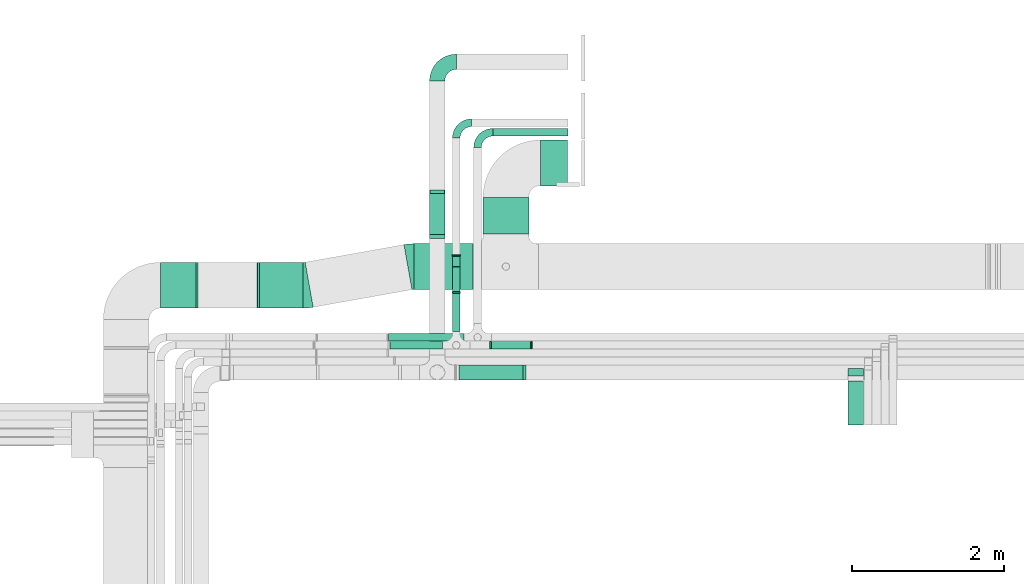
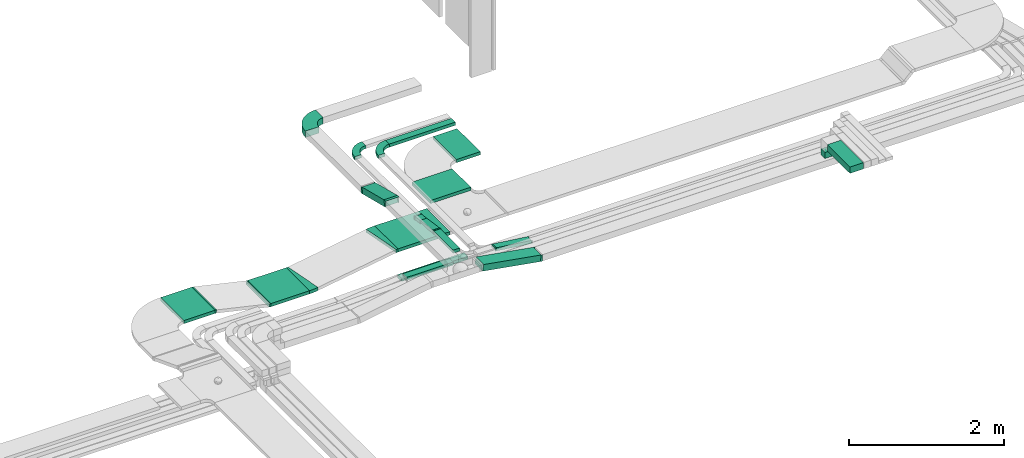
# One storey, part 16 of 38: 16 flow segments, 14 flow fittings.
"""IFC2X3 building model written with IfcOpenShell, lengths in millimetres."""

from ifc_helpers import new_model, entity, si_unit, converted_unit, derived_unit, direction, frame, frame_2d, origin, origin_2d_with_axis, place, context, subcontext, project, spatial, polyline, circle_curve, parameter, trimmed, segment, composite_curve, rectangle, outline, extrude, faceted_brep, source, transform, mapped, material, type_object, type_shapes, element, save


model = new_model("IFC2X3")

# Units and contexts
model_context = context("Model", 3, precision=0.01, world=origin(), true_north=direction((6.12303176911189e-17, 1.0)))
body_context = subcontext(model_context, "Body", "Model", "MODEL_VIEW")
ifc_project = project(units=[si_unit("LENGTHUNIT", "METRE", prefix="MILLI"), si_unit("AREAUNIT", "SQUARE_METRE"), si_unit("VOLUMEUNIT", "CUBIC_METRE"), converted_unit("PLANEANGLEUNIT", "DEGREE", entity("IfcRatioMeasure", 0.0174532925199433), si_unit("PLANEANGLEUNIT", "RADIAN"), dimensions=[0, 0, 0, 0, 0, 0, 0]), si_unit("MASSUNIT", "GRAM", prefix="KILO"), derived_unit("MASSDENSITYUNIT", [(si_unit("MASSUNIT", "GRAM", prefix="KILO"), 1), (si_unit("LENGTHUNIT", "METRE"), -3)]), derived_unit("MOMENTOFINERTIAUNIT", [(si_unit("LENGTHUNIT", "METRE"), 4)]), si_unit("TIMEUNIT", "SECOND"), si_unit("FREQUENCYUNIT", "HERTZ"), si_unit("THERMODYNAMICTEMPERATUREUNIT", "DEGREE_CELSIUS"), derived_unit("THERMALTRANSMITTANCEUNIT", [(si_unit("MASSUNIT", "GRAM", prefix="KILO"), 1), (si_unit("THERMODYNAMICTEMPERATUREUNIT", "KELVIN"), -1), (si_unit("TIMEUNIT", "SECOND"), -3)]), derived_unit("VOLUMETRICFLOWRATEUNIT", [(si_unit("LENGTHUNIT", "METRE"), 3), (si_unit("TIMEUNIT", "SECOND"), -1)]), derived_unit("MASSFLOWRATEUNIT", [(si_unit("MASSUNIT", "GRAM", prefix="KILO"), 1), (si_unit("TIMEUNIT", "SECOND"), -1)]), derived_unit("ROTATIONALFREQUENCYUNIT", [(si_unit("TIMEUNIT", "SECOND"), -1)]), si_unit("ELECTRICCURRENTUNIT", "AMPERE"), si_unit("ELECTRICVOLTAGEUNIT", "VOLT"), si_unit("POWERUNIT", "WATT"), si_unit("FORCEUNIT", "NEWTON", prefix="KILO"), si_unit("ILLUMINANCEUNIT", "LUX"), si_unit("LUMINOUSFLUXUNIT", "LUMEN"), si_unit("LUMINOUSINTENSITYUNIT", "CANDELA"), derived_unit("USERDEFINED", [(si_unit("MASSUNIT", "GRAM", prefix="KILO"), -1), (si_unit("LENGTHUNIT", "METRE"), -2), (si_unit("TIMEUNIT", "SECOND"), 3), (si_unit("LUMINOUSFLUXUNIT", "LUMEN"), 1)]), derived_unit("LINEARVELOCITYUNIT", [(si_unit("LENGTHUNIT", "METRE"), 1), (si_unit("TIMEUNIT", "SECOND"), -1)]), si_unit("PRESSUREUNIT", "PASCAL"), derived_unit("USERDEFINED", [(si_unit("LENGTHUNIT", "METRE"), -2), (si_unit("MASSUNIT", "GRAM", prefix="KILO"), 1), (si_unit("TIMEUNIT", "SECOND"), -2)]), derived_unit("LINEARFORCEUNIT", [(si_unit("MASSUNIT", "GRAM", prefix="KILO"), 1), (si_unit("LENGTHUNIT", "METRE"), 1), (si_unit("TIMEUNIT", "SECOND"), -2), (si_unit("LENGTHUNIT", "METRE"), -1)]), derived_unit("PLANARFORCEUNIT", [(si_unit("MASSUNIT", "GRAM", prefix="KILO"), 1), (si_unit("LENGTHUNIT", "METRE"), 1), (si_unit("TIMEUNIT", "SECOND"), -2), (si_unit("LENGTHUNIT", "METRE"), -2)])], contexts=[model_context])

# Site, building, storey
site_placement = place(None, frame((0.0, -0.00077364408347762, 0.0)))
site = spatial("IfcSite", under=ifc_project, at=site_placement, CompositionType="ELEMENT")
building_placement = place(site_placement, origin())
building = spatial("IfcBuilding", under=site, at=building_placement, CompositionType="ELEMENT")
storey_placement = place(building_placement, frame((0.0, 0.0, 4200.0)))
storey = spatial("IfcBuildingStorey", under=building, at=storey_placement, CompositionType="ELEMENT", Elevation=4200.0)

# Flow segments
cable_carrier_segment_type = type_object("IfcCableCarrierSegmentType", PredefinedType="CABLETRAYSEGMENT")
flow_segment_1_placement = place(storey_placement, frame((15312.7657974395, 14643.1251604397, 2750.0)))
element("IfcFlowSegment", 1, at=flow_segment_1_placement, inside=storey, type_object=cable_carrier_segment_type, context=body_context, shape_type="SweptSolid", body=[
    extrude(rectangle(XDim=984.53996868844, YDim=99.9999999999989, at=frame_2d((-1.08002495835535e-12, 0.0), x_axis=(1.0, 0.0))), frame((492.269984344219, 50.0, 0.0)), (0.0, 0.0, 1.0), 49.9999999999984),
])
flow_segment_2_placement = place(storey_placement, frame((14852.3636804267, 11443.7857236441, 2753.1615431413)))
element("IfcFlowSegment", 2, at=flow_segment_2_placement, inside=storey, type_object=cable_carrier_segment_type, context=body_context, shape_type="SweptSolid", body=[
    extrude(rectangle(XDim=100.000000000001, YDim=200.000000000002, at=frame_2d((0.0, 0.0), x_axis=(0.0, 1.0))), frame((8.58684589014855, 100.0, 198.477684609281), z_axis=(0.985142848049724, 0.0, -0.171736917803013), x_axis=(0.0, 1.0, 0.0)), (0.0, 0.0, 1.0), 868.89030102402),
])
flow_segment_3_placement = place(storey_placement, frame((14483.5407015969, 13326.1095944991, 2759.67031891882)))
element("IfcFlowSegment", 3, at=flow_segment_3_placement, inside=storey, type_object=cable_carrier_segment_type, context=body_context, shape_type="SweptSolid", body=[
    extrude(rectangle(XDim=100.000000000002, YDim=582.930411199209, at=frame_2d((1.4210854715202e-13, -5.25801624462474e-13), x_axis=(0.0, 1.0))), frame((0.0, 294.883802112857, 119.267996271223), z_axis=(1.0, 0.0, 0.0), x_axis=(0.0, -0.970079574867707, 0.242787187521269)), (0.0, 0.0, 1.0), 200.000000000002),
])
flow_segment_4_placement = place(storey_placement, frame((14783.0702916723, 12081.5299176424, 2820.0)))
element("IfcFlowSegment", 4, at=flow_segment_4_placement, inside=storey, type_object=cable_carrier_segment_type, context=body_context, shape_type="SweptSolid", body=[
    extrude(rectangle(XDim=498.584112619175, YDim=99.9999999999989, at=frame_2d((1.08002495835535e-12, -1.08357767203415e-12), x_axis=(1.0, 0.0))), frame((50.0, 249.292056309587, 0.0), z_axis=(0.0, 0.0, 1.0), x_axis=(0.0, 1.0, 0.0)), (0.0, 0.0, 1.0), 49.9999999999995),
])
flow_segment_5_placement = place(storey_placement, frame((14783.0702916723, 12594.3139260251, 2800.0)))
element("IfcFlowSegment", 5, at=flow_segment_5_placement, inside=storey, type_object=cable_carrier_segment_type, context=body_context, shape_type="SweptSolid", body=[
    extrude(outline(polyline([(-175.752920097697, -24.1729973067359), (161.845119537904, -24.1729973067359), (161.845119537905, 25.8270026932638), (27.815601119587, 25.8270026932639), (-175.752920097698, -3.30801077305341), (-175.752920097697, -24.1729973067359)])), frame((0.0, 163.871672192464, 21.6256305644441), z_axis=(1.0, 0.0, 0.0), x_axis=(0.0, -0.989912836483268, 0.141677719369175)), (0.0, 0.0, 1.0), 99.9999999999989),
])
flow_segment_6_placement = place(storey_placement, frame((13960.8930525177, 11851.5299176424, 2820.0)))
element("IfcFlowSegment", 6, at=flow_segment_6_placement, inside=storey, type_object=cable_carrier_segment_type, context=body_context, shape_type="SweptSolid", body=[
    extrude(rectangle(XDim=692.177239154652, YDim=99.9999999999989, at=frame_2d((0.0, 1.08357767203415e-12), x_axis=(1.0, 0.0))), frame((346.088619577326, 50.0, 0.0), z_axis=(0.0, 0.0, 1.0), x_axis=(-1.0, 0.0, 0.0)), (0.0, 0.0, 1.0), 49.9999999999995),
])
flow_segment_7_placement = place(storey_placement, frame((15288.0548874879, 11851.5299176424, 2751.30556096774)))
element("IfcFlowSegment", 7, at=flow_segment_7_placement, inside=storey, type_object=cable_carrier_segment_type, context=body_context, shape_type="SweptSolid", body=[
    extrude(rectangle(XDim=50.0000000000006, YDim=99.9999999999989, at=origin_2d_with_axis()), frame((3.21220986557386, 50.0, 92.5961027503563), z_axis=(0.991711012567267, 0.0, -0.128488394623039), x_axis=(0.128488394623039, 0.0, 0.991711012567267)), (0.0, 0.0, 1.0), 527.700012402662),
])
flow_segment_8_placement = place(storey_placement, frame((15184.0814441513, 13362.0485020162, 2682.77089996955)))
element("IfcFlowSegment", 8, at=flow_segment_8_placement, inside=storey, type_object=cable_carrier_segment_type, context=body_context, shape_type="SweptSolid", body=[
    extrude(rectangle(XDim=479.00000000001, YDim=600.000000000002, at=frame_2d((1.08002495835535e-12, 0.0), x_axis=(1.0, 0.0))), frame((300.0, 239.500000000006, 0.0), z_axis=(0.0, 0.0, 1.0), x_axis=(0.0, 1.0, 0.0)), (0.0, 0.0, 1.0), 49.9999999999995),
])
flow_segment_9_placement = place(storey_placement, frame((15935.0814441513, 13992.0485020162, 2682.77089996955)))
element("IfcFlowSegment", 9, at=flow_segment_9_placement, inside=storey, type_object=cable_carrier_segment_type, context=body_context, shape_type="SweptSolid", body=[
    extrude(rectangle(XDim=354.000000000017, YDim=600.000000000002, at=frame_2d((-1.08002495835535e-12, 0.0), x_axis=(1.0, 0.0))), frame((177.0, 300.0, 0.0)), (0.0, 0.0, 1.0), 49.9999999999984),
])
flow_segment_10_placement = place(storey_placement, frame((14279.8451383887, 12632.0485020162, 2682.77089996955)))
element("IfcFlowSegment", 10, at=flow_segment_10_placement, inside=storey, type_object=cable_carrier_segment_type, context=body_context, shape_type="SweptSolid", body=[
    extrude(rectangle(XDim=774.236305762649, YDim=599.999999999998, at=frame_2d((-1.08002495835535e-12, 0.0), x_axis=(1.0, 0.0))), frame((387.118152881325, 300.0, 0.0), z_axis=(0.0, 0.0, 1.0), x_axis=(-1.0, 0.0, 0.0)), (0.0, 0.0, 1.0), 49.9999999999995),
])
flow_segment_11_placement = place(storey_placement, frame((14783.0702916724, 12928.506559032, 2751.51536167819)))
element("IfcFlowSegment", 11, at=flow_segment_11_placement, inside=storey, type_object=cable_carrier_segment_type, context=body_context, shape_type="SweptSolid", body=[
    extrude(rectangle(XDim=49.9999999999997, YDim=138.649285066517, at=frame_2d((1.07291953099775e-12, 1.54543045027822e-13), x_axis=(0.0, 1.0))), frame((0.0, 72.1672965125303, 34.5695781622768), z_axis=(1.0, 0.0, 0.0), x_axis=(0.0, -0.989912836483268, 0.141677719369175)), (0.0, 0.0, 1.0), 99.9999999999989),
])
flow_segment_12_placement = place(storey_placement, frame((13940.8033469853, 11954.0299176424, 2750.0)))
element("IfcFlowSegment", 12, at=flow_segment_12_placement, inside=storey, type_object=cable_carrier_segment_type, context=body_context, shape_type="SweptSolid", body=[
    extrude(rectangle(XDim=990.962450454234, YDim=99.9999999999989, at=frame_2d((0.0, -1.08357767203415e-12), x_axis=(1.0, 0.0))), frame((495.481225227117, 50.0, 0.0), z_axis=(0.0, 0.0, 1.0), x_axis=(-1.0, 0.0, 0.0)), (0.0, 0.0, 1.0), 49.9999999999995),
])
flow_segment_13_placement = place(storey_placement, frame((10954.5911506353, 12387.0485020162, 2868.05744873961)))
element("IfcFlowSegment", 13, at=flow_segment_13_placement, inside=storey, type_object=cable_carrier_segment_type, context=body_context, shape_type="SweptSolid", body=[
    extrude(rectangle(XDim=463.236536668238, YDim=600.000000000002, at=frame_2d((1.08002495835535e-12, 0.0), x_axis=(1.0, 0.0))), frame((231.61826833412, 300.0, 0.0)), (0.0, 0.0, 1.0), 49.9999999999995),
])
flow_segment_14_placement = place(storey_placement, frame((12250.0044205776, 12387.0485020162, 2682.77089996955)))
element("IfcFlowSegment", 14, at=flow_segment_14_placement, inside=storey, type_object=cable_carrier_segment_type, context=body_context, shape_type="SweptSolid", body=[
    extrude(rectangle(XDim=572.823035820443, YDim=600.000000000002, at=origin_2d_with_axis()), frame((286.411517910222, 300.0, 0.0), z_axis=(0.0, 0.0, 1.0), x_axis=(-1.0, 0.0, 0.0)), (0.0, 0.0, 1.0), 49.9999999999995),
])
flow_segment_15_placement = place(storey_placement, frame((19972.9316203514, 10851.673044066, 3005.0)))
element("IfcFlowSegment", 15, at=flow_segment_15_placement, inside=storey, type_object=cable_carrier_segment_type, context=body_context, shape_type="SweptSolid", body=[
    extrude(rectangle(XDim=582.112679578124, YDim=199.999999999998, at=frame_2d((-2.1600499167107e-12, -2.16715534406831e-12), x_axis=(1.0, 0.0))), frame((100.0, 291.056339789061, 0.0), z_axis=(0.0, 0.0, 1.0), x_axis=(0.0, -1.0, 0.0)), (0.0, 0.0, 1.0), 99.9999999999978),
])
flow_segment_16_placement = place(storey_placement, frame((19972.9316203514, 11493.7857236441, 2850.0)))
element("IfcFlowSegment", 16, at=flow_segment_16_placement, inside=storey, type_object=cable_carrier_segment_type, context=body_context, shape_type="SweptSolid", body=[
    extrude(rectangle(XDim=199.999999999998, YDim=99.9999999999989, at=origin_2d_with_axis()), frame((100.0, 50.0, 0.0), z_axis=(0.0, 0.0, 1.0), x_axis=(-1.0, 0.0, 0.0)), (0.0, 0.0, 1.0), 94.9999999999979),
])

# Flow fittings
ifc_material = material()
cable_carrier_fitting_type_1 = type_object("IfcCableCarrierFittingType", Name="470_DKC_S5_Variable Angle Elbow 0-45:-", PredefinedType="NOTDEFINED", material=ifc_material)
shared_shape_1 = source(origin(), body_context, "Body", "SweptSolid", [
    extrude(outline(composite_curve([segment(polyline([(-125.750000000001, -225.25), (-124.749999999999, -225.25)]), True, "CONTINUOUS"), segment(trimmed(circle_curve(frame_2d((-124.75, 124.75), x_axis=(0.0, -1.0)), 350.0), [parameter(0.0)], [parameter(90.0000000000001)], True, "PARAMETER"), True, "CONTINUOUS"), segment(polyline([(225.25, 124.75), (225.25, 125.749999999999)]), True, "CONTINUOUS"), segment(polyline([(225.25, 125.749999999999), (25.25, 125.750000000001)]), True, "CONTINUOUS"), segment(polyline([(25.25, 125.750000000001), (25.25, 124.75)]), True, "CONTINUOUS"), segment(trimmed(circle_curve(frame_2d((-124.75, 124.75), x_axis=(0.0, -1.0)), 150.0), [parameter(0.0)], [parameter(90.0000000000001)], True, "PARAMETER"), False, "CONTINUOUS"), segment(polyline([(-124.749999999999, -25.2500000000003), (-125.750000000001, -25.2500000000003)]), True, "CONTINUOUS"), segment(polyline([(-125.750000000001, -25.2500000000003), (-125.750000000001, -225.25)]), True, "CONTINUOUS")], self_intersect=False)), frame((-125.249999999991, 125.249999999992, -50.0)), (0.0, 0.0, 1.0), 100.0),
])
type_shapes(cable_carrier_fitting_type_1, [shared_shape_1])
flow_fitting_1_placement = place(storey_placement, frame((14583.5407015969, 15618.1251604396, 2803.81871708572), z_axis=(0.0, 0.0, 1.0), x_axis=(-1.0, 0.0, 0.0)))
element("IfcFlowFitting", 17, at=flow_fitting_1_placement, inside=storey, type_object=cable_carrier_fitting_type_1, material=ifc_material, Name="470_DKC_S5_Variable Angle Elbow 0-45:-", ObjectType="470_DKC_S5_Variable Angle Elbow 0-45:-", context=body_context, shape_type="MappedRepresentation", body=[
    mapped(shared_shape_1, transform((0.0, 0.0, 0.0), scale=1.0)),
])
cable_carrier_fitting_type_2 = type_object("IfcCableCarrierFittingType", Name="470_DKC_S5_Variable Angle Elbow 0-45:-", PredefinedType="NOTDEFINED", material=ifc_material)
shared_shape_2 = source(origin(), body_context, "Body", "SweptSolid", [
    extrude(outline(composite_curve([segment(polyline([(-100.750000000001, -150.25), (-99.7499999999994, -150.25)]), True, "CONTINUOUS"), segment(trimmed(circle_curve(frame_2d((-99.7499999999997, 99.7499999999995), x_axis=(0.0, -1.0)), 250.0), [parameter(0.0)], [parameter(90.0000000000001)], True, "PARAMETER"), True, "CONTINUOUS"), segment(polyline([(150.25, 99.75), (150.25, 100.749999999999)]), True, "CONTINUOUS"), segment(polyline([(150.25, 100.749999999999), (50.25, 100.75)]), True, "CONTINUOUS"), segment(polyline([(50.25, 100.75), (50.25, 99.7499999999998)]), True, "CONTINUOUS"), segment(trimmed(circle_curve(frame_2d((-99.7499999999997, 99.7499999999995), x_axis=(0.0, -1.0)), 150.0), [parameter(0.0)], [parameter(90.0000000000001)], True, "PARAMETER"), False, "CONTINUOUS"), segment(polyline([(-99.7499999999994, -50.2500000000003), (-100.750000000001, -50.2500000000003)]), True, "CONTINUOUS"), segment(polyline([(-100.750000000001, -50.2500000000003), (-100.750000000001, -150.25)]), True, "CONTINUOUS")], self_intersect=False)), frame((-100.249999999991, 100.249999999992, -25.0)), (0.0, 0.0, 1.0), 49.9999999999997),
])
type_shapes(cable_carrier_fitting_type_2, [shared_shape_2])
for number, where, z_axis, x_axis, name in (
    (18, (14833.0702916724, 14818.1251604396, 2775.0), (0.0, 0.0, 1.0), (-1.0, 0.0, 0.0), "470_DKC_S5_Variable Angle Elbow 0-45:-"),
    (19, (15111.7657974395, 14693.1251604396, 2775.0), (0.0, 0.0, 1.0), (-1.0, 0.0, 0.0), "470_DKC_S5_Variable Angle Elbow 0-45:-"),
):
    element("IfcFlowFitting", number, at=place(storey_placement, frame(where, z_axis=z_axis, x_axis=x_axis)), inside=storey, type_object=cable_carrier_fitting_type_2, material=ifc_material, Name=name, ObjectType="470_DKC_S5_Variable Angle Elbow 0-45:-", context=body_context, shape_type="MappedRepresentation", body=[
        mapped(shared_shape_2, transform((0.0, 0.0, 0.0), scale=1.0)),
    ])
cable_carrier_fitting_type_3 = type_object("IfcCableCarrierFittingType", PredefinedType="NOTDEFINED", material=ifc_material)
shared_shape_3 = source(origin(), body_context, "Body", "Brep", [
    faceted_brep([(-14.083666894315, -50.0, 100.0), (-14.0836668943147, 50.0, 100.0), (-14.0836668943147, 50.0, 97.4600000101635), (-14.083666894315, -47.4600000101599, 97.4600000101635), (-14.083666894315, -47.4600000101599, -97.4600000101564), (-14.0836668943147, 50.0, -97.4600000101564), (-14.0836668943147, 50.0, -100.0), (-14.083666894315, -50.0, -100.0), (22.4612696054003, -46.8384568586927, 100.0), (22.4612696054003, -46.8384568586927, -100.0), (5.28757782509931, 51.6758279462797, -100.0), (5.28757782509931, 51.6758279462797, -97.4600000101564), (22.0250578359255, -44.3361940346554, -97.4600000101564), (22.0250578359255, -44.3361940346554, 97.4600000101635), (5.28757782509931, 51.6758279462797, 97.4600000101635), (5.2875778250993, 51.6758279462798, 100.0), (4.32555566395999, -50.0, 100.0), (-4.32555566395925, 50.0, 100.0), (-4.32555566395925, 50.0, 97.4600000101635), (4.10581743710975, -47.46000001016, 97.4600000101635), (4.10581743710975, -47.46000001016, -97.4600000101564), (-4.32555566395925, 50.0, -97.4600000101564), (-4.32555566395925, 50.0, -100.0), (4.32555566395995, -50.0, -100.0)], [[[0, 1, 2, 3, 4, 5, 6, 7]], [[8, 9, 10, 11, 12, 13, 14, 15]], [[1, 0, 16, 8, 15, 17]], [[2, 1, 17, 18]], [[3, 2, 18, 14, 13, 19]], [[4, 3, 19, 20]], [[5, 4, 20, 12, 11, 21]], [[6, 5, 21, 22]], [[7, 6, 22, 10, 9, 23]], [[0, 7, 23, 16]], [[18, 17, 15, 14]], [[20, 19, 13, 12]], [[22, 21, 11, 10]], [[16, 23, 9, 8]]]),
])
type_shapes(cable_carrier_fitting_type_3, [shared_shape_3])
flow_fitting_2_placement = place(storey_placement, frame((15730.8060158257, 11543.7857236441, 2800.0), z_axis=(0.0, -1.0, 0.0), x_axis=(0.985142848049724, 0.0, -0.17173691780301)))
element("IfcFlowFitting", 20, at=flow_fitting_2_placement, inside=storey, type_object=cable_carrier_fitting_type_3, material=ifc_material, context=body_context, shape_type="MappedRepresentation", body=[
    mapped(shared_shape_3, transform((0.0, 0.0, 0.0), scale=1.0)),
])
cable_carrier_fitting_type_4 = type_object("IfcCableCarrierFittingType", PredefinedType="NOTDEFINED", material=ifc_material)
shared_shape_4 = source(origin(), body_context, "Body", "Brep", [
    faceted_brep([(-17.9399111665075, -50.0, 100.0), (-17.9399111665071, 50.0, 100.0), (-17.9399111665071, 50.0, 97.4600000101635), (-17.9399111665074, -47.4600000101599, 97.4600000101635), (-17.9399111665074, -47.4600000101599, -97.4600000101564), (-17.9399111665071, 50.0, -97.4600000101564), (-17.9399111665071, 50.0, -100.0), (-17.9399111665075, -50.0, -100.0), (29.5425007736367, -44.1483981668863, 100.0), (29.5425007736367, -44.1483981668863, -100.0), (5.26378202150415, 52.859559319883, -100.0), (5.26378202150415, 52.8595593198831, -97.4600000101564), (28.9258213197993, -41.6843960565784, -97.4600000101565), (28.9258213197993, -41.6843960565784, 97.4600000101635), (5.26378202150415, 52.859559319883, 97.4600000101635), (5.26378202150415, 52.8595593198831, 100.0), (6.16186246024208, -50.0, 100.0), (-6.16186246024132, 50.0, 100.0), (-6.16186246024132, 50.0, 97.4600000101635), (5.84883984851384, -47.46000001016, 97.4600000101635), (5.84883984851384, -47.46000001016, -97.4600000101564), (-6.16186246024132, 50.0, -97.4600000101564), (-6.16186246024132, 50.0, -100.0), (6.16186246024203, -50.0, -100.0)], [[[0, 1, 2, 3, 4, 5, 6, 7]], [[8, 9, 10, 11, 12, 13, 14, 15]], [[1, 0, 16, 8, 15, 17]], [[2, 1, 17, 18]], [[3, 2, 18, 14, 13, 19]], [[4, 3, 19, 20]], [[5, 4, 20, 12, 11, 21]], [[6, 5, 21, 22]], [[7, 6, 22, 10, 9, 23]], [[0, 7, 23, 16]], [[18, 17, 15, 14]], [[20, 19, 13, 12]], [[22, 21, 11, 10]], [[16, 23, 9, 8]]]),
])
type_shapes(cable_carrier_fitting_type_4, [shared_shape_4])
for number, where, z_axis, x_axis in (
    (21, (14583.5407015969, 13320.8458124776, 2954.05791329438), (-1.0, 0.0, 0.0), (0.0, 1.0, 0.0)),
    (22, (14583.5407015969, 13921.1409807463, 2803.81871708571), (1.0, 0.0, 0.0), (0.0, 0.970079574867707, -0.242787187521269)),
):
    element("IfcFlowFitting", number, at=place(storey_placement, frame(where, z_axis=z_axis, x_axis=x_axis)), inside=storey, type_object=cable_carrier_fitting_type_4, material=ifc_material, context=body_context, shape_type="MappedRepresentation", body=[
        mapped(shared_shape_4, transform((0.0, 0.0, 0.0), scale=1.0)),
    ])
cable_carrier_fitting_type_5 = type_object("IfcCableCarrierFittingType", PredefinedType="NOTDEFINED", material=ifc_material)
shared_shape_5 = source(origin(), body_context, "Body", "Brep", [
    faceted_brep([(-8.91588738081413, -25.0, 50.0), (-8.91588738081396, 25.0, 50.0), (-8.91588738081396, 25.0, 47.4600000101635), (-8.91588738081412, -22.46000001016, 47.4600000101635), (-8.91588738081412, -22.46000001016, -47.4600000101565), (-8.91588738081396, 25.0, -47.4600000101565), (-8.91588738081396, 25.0, -50.0), (-8.91588738081413, -25.0, -50.0), (12.3678943511375, -23.4846383218158, 50.0), (12.3678943511375, -23.4846383218158, -50.0), (5.28400838267802, 26.0110035023475, -50.0), (5.28400838267802, 26.0110035023475, -47.4600000101565), (12.0080329453792, -20.9702597272058, -47.4600000101565), (12.0080329453792, -20.9702597272058, 47.4600000101635), (5.28400838267802, 26.0110035023475, 47.4600000101635), (5.28400838267802, 26.0110035023475, 50.0), (1.77994880946146, -25.0, 50.0), (-1.77994880946072, 25.0, 50.0), (-1.77994880946072, 25.0, 47.4600000101635), (1.59910601114355, -22.46000001016, 47.4600000101635), (1.59910601114355, -22.46000001016, -47.4600000101565), (-1.77994880946072, 25.0, -47.4600000101565), (-1.77994880946072, 25.0, -50.0), (1.77994880946143, -25.0, -50.0)], [[[0, 1, 2, 3, 4, 5, 6, 7]], [[8, 9, 10, 11, 12, 13, 14, 15]], [[1, 0, 16, 8, 15, 17]], [[2, 1, 17, 18]], [[3, 2, 18, 14, 13, 19]], [[4, 3, 19, 20]], [[5, 4, 20, 12, 11, 21]], [[6, 5, 21, 22]], [[7, 6, 22, 10, 9, 23]], [[0, 7, 23, 16]], [[18, 17, 15, 14]], [[20, 19, 13, 12]], [[22, 21, 11, 10]], [[16, 23, 9, 8]]]),
])
type_shapes(cable_carrier_fitting_type_5, [shared_shape_5])
for number, where, z_axis, x_axis in (
    (23, (14833.0702916724, 13078.1251604397, 2775.0), (-1.0, 0.0, 0.0), (0.0, -1.0, 0.0)),
    (24, (14833.0702916723, 12589.0299176424, 2845.0), (-1.0, 0.0, 0.0), (0.0, 1.0, 0.0)),
):
    element("IfcFlowFitting", number, at=place(storey_placement, frame(where, z_axis=z_axis, x_axis=x_axis)), inside=storey, type_object=cable_carrier_fitting_type_5, material=ifc_material, context=body_context, shape_type="MappedRepresentation", body=[
        mapped(shared_shape_5, transform((0.0, 0.0, 0.0), scale=1.0)),
    ])
cable_carrier_fitting_type_6 = type_object("IfcCableCarrierFittingType", PredefinedType="NOTDEFINED", material=ifc_material)
shared_shape_6 = source(origin(), body_context, "Body", "Brep", [
    faceted_brep([(-8.54813607982132, -25.0, 50.0), (-8.54813607982116, 25.0, 50.0), (-8.54813607982116, 25.0, 47.4600000101635), (-8.54813607982131, -22.46000001016, 47.4600000101635), (-8.54813607982131, -22.46000001016, -47.4600000101565), (-8.54813607982116, 25.0, -47.4600000101565), (-8.54813607982116, 25.0, -50.0), (-8.54813607982132, -25.0, -50.0), (11.6894905528594, -23.6944390322664, 50.0), (11.6894905528594, -23.6944390322664, -50.0), (5.26507082170674, 25.8911115960968, -50.0), (5.26507082170673, 25.8911115960969, -47.4600000101565), (11.3631300318223, -21.1754930704214, -47.4600000101565), (11.3631300318223, -21.1754930704214, 47.4600000101635), (5.26507082170674, 25.8911115960968, 47.4600000101635), (5.26507082170674, 25.8911115960968, 50.0), (1.61278912719199, -25.0, 50.0), (-1.61278912719124, 25.0, 50.0), (-1.61278912719124, 25.0, 47.4600000101635), (1.44892975252473, -22.46000001016, 47.4600000101635), (1.44892975252473, -22.46000001016, -47.4600000101565), (-1.61278912719124, 25.0, -47.4600000101565), (-1.61278912719124, 25.0, -50.0), (1.61278912719196, -25.0, -50.0)], [[[0, 1, 2, 3, 4, 5, 6, 7]], [[8, 9, 10, 11, 12, 13, 14, 15]], [[1, 0, 16, 8, 15, 17]], [[2, 1, 17, 18]], [[3, 2, 18, 14, 13, 19]], [[4, 3, 19, 20]], [[5, 4, 20, 12, 11, 21]], [[6, 5, 21, 22]], [[7, 6, 22, 10, 9, 23]], [[0, 7, 23, 16]], [[18, 17, 15, 14]], [[20, 19, 13, 12]], [[22, 21, 11, 10]], [[16, 23, 9, 8]]]),
])
type_shapes(cable_carrier_fitting_type_6, [shared_shape_6])
for number, where, z_axis, x_axis in (
    (25, (15823.0702916723, 11901.5299176424, 2775.0), (0.0, 1.0, 0.0), (-1.0, 0.0, 0.0)),
    (26, (15282.7898166661, 11901.5299176424, 2845.0), (0.0, -1.0, 0.0), (-0.991711012567267, 0.0, 0.128488394623036)),
):
    element("IfcFlowFitting", number, at=place(storey_placement, frame(where, z_axis=z_axis, x_axis=x_axis)), inside=storey, type_object=cable_carrier_fitting_type_6, material=ifc_material, context=body_context, shape_type="MappedRepresentation", body=[
        mapped(shared_shape_6, transform((0.0, 0.0, 0.0), scale=1.0)),
    ])
cable_carrier_fitting_type_7 = type_object("IfcCableCarrierFittingType", Name="470_DKC_S5_Variable Angle Elbow 0-45:-", PredefinedType="NOTDEFINED", material=ifc_material)
shared_shape_7 = source(origin(), body_context, "Body", "SweptSolid", [
    extrude(outline(composite_curve([segment(polyline([(-40.4517448228728, -303.530286589744), (-39.4517448228708, -303.530286589744)]), True, "CONTINUOUS"), segment(trimmed(circle_curve(frame_2d((-39.4517448228465, 446.469713410256), x_axis=(0.0, -1.0)), 750.0), [parameter(0.0)], [parameter(10.0995099197509)], True, "PARAMETER"), True, "CONTINUOUS"), segment(polyline([(92.0669840200496, -291.908796544868), (93.051488699989, -291.733438239744)]), True, "CONTINUOUS"), segment(polyline([(93.051488699989, -291.733438239744), (-12.1634943743263, 298.969369724355)]), True, "CONTINUOUS"), segment(polyline([(-12.1634943743263, 298.969369724355), (-13.1479990542673, 298.794011419231)]), True, "CONTINUOUS"), segment(trimmed(circle_curve(frame_2d((-39.4517448228465, 446.469713410256), x_axis=(0.0, -1.0)), 150.0), [parameter(0.0)], [parameter(10.0995099197509)], True, "PARAMETER"), False, "CONTINUOUS"), segment(polyline([(-39.4517448228505, 296.469713410256), (-40.4517448228525, 296.469713410256)]), True, "CONTINUOUS"), segment(polyline([(-40.4517448228525, 296.469713410256), (-40.4517448228728, -303.530286589744)]), True, "CONTINUOUS")], self_intersect=False)), frame((-0.311949414489405, 3.53028658973707, -25.0)), (0.0, 0.0, 1.0), 50.0000000000017),
])
type_shapes(cable_carrier_fitting_type_7, [shared_shape_7])
flow_fitting_3_placement = place(storey_placement, frame((14239.0814441513, 12932.0485020162, 2707.77089996956), z_axis=(0.0, 0.0, 1.0), x_axis=(-1.0, 0.0, 0.0)))
element("IfcFlowFitting", 27, at=flow_fitting_3_placement, inside=storey, type_object=cable_carrier_fitting_type_7, material=ifc_material, Name="470_DKC_S5_Variable Angle Elbow 0-45:-", ObjectType="470_DKC_S5_Variable Angle Elbow 0-45:-", context=body_context, shape_type="MappedRepresentation", body=[
    mapped(shared_shape_7, transform((0.0, 0.0, 0.0), scale=1.0)),
])
flow_fitting_4_placement = place(storey_placement, frame((12863.5911506354, 12687.0485020162, 2707.77089996956)))
element("IfcFlowFitting", 28, at=flow_fitting_4_placement, inside=storey, type_object=cable_carrier_fitting_type_7, material=ifc_material, Name="470_DKC_S5_Variable Angle Elbow 0-45:-", ObjectType="470_DKC_S5_Variable Angle Elbow 0-45:-", context=body_context, shape_type="MappedRepresentation", body=[
    mapped(shared_shape_7, transform((0.0, 0.0, 0.0), scale=1.0)),
])
cable_carrier_fitting_type_8 = type_object("IfcCableCarrierFittingType", PredefinedType="NOTDEFINED", material=ifc_material)
shared_shape_8 = source(origin(), body_context, "Body", "Brep", [
    faceted_brep([(-11.2122395346818, -25.0, 300.0), (-11.2122395346816, 25.0, 300.0), (-11.2122395346816, 25.0, 297.460000010164), (-11.2122395346818, -22.46000001016, 297.460000010164), (-11.2122395346818, -22.46000001016, -297.460000010156), (-11.2122395346816, 25.0, -297.460000010156), (-11.2122395346816, 25.0, -300.0), (-11.2122395346818, -25.0, -300.0), (16.5061087707275, -21.8692178331105, 300.0), (16.5061087707275, -21.8692178331105, -300.0), (5.35341013051599, 26.8710869775965, -300.0), (5.35341013051598, 26.8710869775965, -297.460000010156), (15.9395516820709, -19.3932103586306, -297.460000010156), (15.9395516820709, -19.3932103586306, 297.460000010164), (5.35341013051599, 26.8710869775965, 297.460000010164), (5.35341013051599, 26.8710869775965, 300.0), (2.82374524303766, -25.0, 300.0), (-2.8237452430369, 25.0, 300.0), (-2.8237452430369, 25.0, 297.460000010164), (2.53685272749259, -22.46000001016, 297.460000010164), (2.53685272749259, -22.46000001016, -297.460000010156), (-2.8237452430369, 25.0, -297.460000010156), (-2.8237452430369, 25.0, -300.0), (2.82374524303761, -25.0, -300.0)], [[[0, 1, 2, 3, 4, 5, 6, 7]], [[8, 9, 10, 11, 12, 13, 14, 15]], [[1, 0, 16, 8, 15, 17]], [[2, 1, 17, 18]], [[3, 2, 18, 14, 13, 19]], [[4, 3, 19, 20]], [[5, 4, 20, 12, 11, 21]], [[6, 5, 21, 22]], [[7, 6, 22, 10, 9, 23]], [[0, 7, 23, 16]], [[18, 17, 15, 14]], [[20, 19, 13, 12]], [[22, 21, 11, 10]], [[16, 23, 9, 8]]]),
])
type_shapes(cable_carrier_fitting_type_8, [shared_shape_8])
for number, where, z_axis, x_axis in (
    (29, (11429.0399268383, 12687.0485020162, 2893.05744873961), (0.0, 1.0, 0.0), (1.0, 0.0, 0.0)),
    (30, (12238.7921810429, 12687.0485020162, 2707.77089996955), (0.0, 1.0, 0.0), (-1.0, 0.0, 0.0)),
):
    element("IfcFlowFitting", number, at=place(storey_placement, frame(where, z_axis=z_axis, x_axis=x_axis)), inside=storey, type_object=cable_carrier_fitting_type_8, material=ifc_material, context=body_context, shape_type="MappedRepresentation", body=[
        mapped(shared_shape_8, transform((0.0, 0.0, 0.0), scale=1.0)),
    ])

save(model, "model.ifc")
